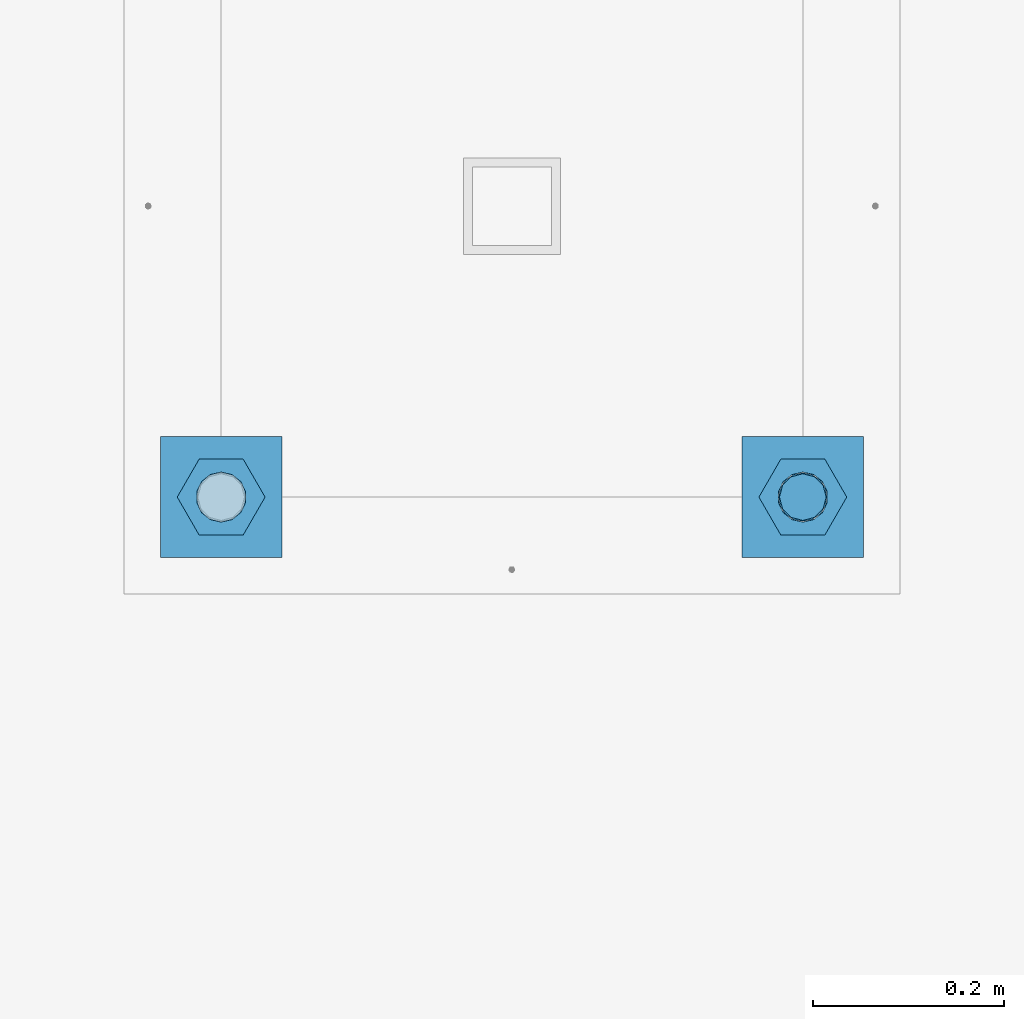
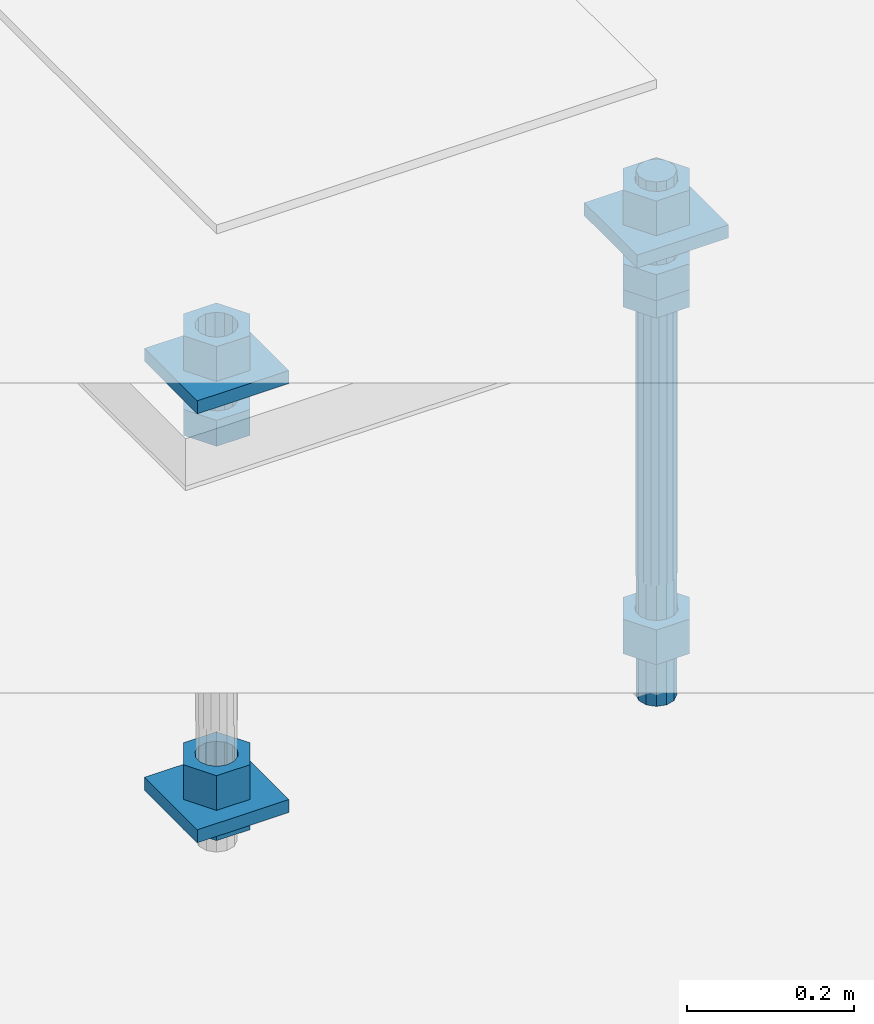
# One storey, part 2733 of 3843: 12 beams, 1 element without a shape of its own.
"""IFC2X3 building model written with IfcOpenShell, lengths in millimetres."""

from ifc_helpers import new_model, si_unit, frame, origin_with_axes, place, context, subcontext, project, spatial, faceted_brep, material, type_object, element, aggregate, save


model = new_model("IFC2X3")

# Units and contexts
model_context = context("Model", 3, precision=1e-05, world=origin_with_axes())
body_context = subcontext(model_context, "Body", "Model", "MODEL_VIEW")
ifc_project = project(units=[si_unit("LENGTHUNIT", "METRE", prefix="MILLI"), si_unit("AREAUNIT", "SQUARE_METRE"), si_unit("VOLUMEUNIT", "CUBIC_METRE"), si_unit("MASSUNIT", "GRAM", prefix="KILO"), si_unit("TIMEUNIT", "SECOND"), si_unit("PLANEANGLEUNIT", "RADIAN"), si_unit("SOLIDANGLEUNIT", "STERADIAN"), si_unit("THERMODYNAMICTEMPERATUREUNIT", "DEGREE_CELSIUS"), si_unit("LUMINOUSINTENSITYUNIT", "LUMEN")], contexts=[model_context])

# Site, building, storey
site_placement = place(None, origin_with_axes())
site = spatial("IfcSite", under=ifc_project, at=site_placement, CompositionType="ELEMENT")
building_placement = place(site_placement, origin_with_axes())
building = spatial("IfcBuilding", under=site, at=building_placement, Name="Undefined", CompositionType="ELEMENT")
storey_placement = place(building_placement, origin_with_axes())
storey = spatial("IfcBuildingStorey", under=building, at=storey_placement, Name="Undefined", CompositionType="ELEMENT", Elevation=0.0)

# Assembly, beams
assembly_placement = place(storey_placement, origin_with_axes())
assembly = element("IfcElementAssembly", 1, at=assembly_placement, inside=storey, Name="TEMPLATE", AssemblyPlace="NOTDEFINED", PredefinedType="RIGID_FRAME")
ifc_material_1 = material(Name="STEEL/A36")
beam_type_1 = type_object("IfcBeamType", PredefinedType="NOTDEFINED")
beam_1_placement = place(assembly_placement, frame((115798.6, 38188.9000015259, 29873.575), z_axis=(1.0, 0.0, 0.0), x_axis=(0.0, 1.0, 0.0)))
beam_1 = element("IfcBeam", 2, at=beam_1_placement, type_object=beam_type_1, material=ifc_material_1, Name="WASHER_PLATE", context=body_context, shape_type="Brep", body=[
    faceted_brep([(0.0, 9.52500000000146, -63.5), (0.0, 9.52500000000146, 63.5), (127.0, 9.52500000000146, 63.5), (127.0, 9.52500000000146, -63.5), (0.0, -9.52500000000146, 63.5), (127.0, -9.52500000000146, 63.5), (0.0, -9.52500000000146, -63.5), (127.0, -9.52500000000146, -63.5)], [[[0, 1, 2, 3]], [[1, 4, 5, 2]], [[4, 6, 7, 5]], [[6, 0, 3, 7]], [[5, 7, 3, 2]], [[6, 4, 1, 0]]]),
])
beam_2_placement = place(assembly_placement, frame((116408.2, 38188.9000015259, 29873.575), z_axis=(1.0, 0.0, 0.0), x_axis=(0.0, 1.0, 0.0)))
beam_2 = element("IfcBeam", 3, at=beam_2_placement, type_object=beam_type_1, material=ifc_material_1, Name="WASHER_PLATE", context=body_context, shape_type="Brep", body=[
    faceted_brep([(0.0, 9.52500000000146, -63.5), (0.0, 9.52500000000146, 63.5), (127.0, 9.52500000000146, 63.5), (127.0, 9.52500000000146, -63.5), (0.0, -9.52500000000146, 63.5), (127.0, -9.52500000000146, 63.5), (0.0, -9.52500000000146, -63.5), (127.0, -9.52500000000146, -63.5)], [[[0, 1, 2, 3]], [[1, 4, 5, 2]], [[4, 6, 7, 5]], [[6, 0, 3, 7]], [[5, 7, 3, 2]], [[6, 4, 1, 0]]]),
])
beam_3_placement = place(assembly_placement, frame((115798.6, 38188.9000015259, 29244.925), z_axis=(1.0, 0.0, 0.0), x_axis=(0.0, 1.0, 0.0)))
beam_3 = element("IfcBeam", 4, at=beam_3_placement, type_object=beam_type_1, material=ifc_material_1, Name="WASHER_PLATE", context=body_context, shape_type="Brep", body=[
    faceted_brep([(0.0, 9.52500000000146, -63.5), (0.0, 9.52500000000146, 63.5), (127.0, 9.52500000000146, 63.5), (127.0, 9.52500000000146, -63.5), (0.0, -9.52500000000146, 63.5), (127.0, -9.52500000000146, 63.5), (0.0, -9.52500000000146, -63.5), (127.0, -9.52500000000146, -63.5)], [[[0, 1, 2, 3]], [[1, 4, 5, 2]], [[4, 6, 7, 5]], [[6, 0, 3, 7]], [[5, 7, 3, 2]], [[6, 4, 1, 0]]]),
])
beam_type_2 = type_object("IfcBeamType", Name="2_HALF_NUT", PredefinedType="NOTDEFINED")
beam_4_placement = place(assembly_placement, frame((116408.2, 38252.4000015259, 29787.85), z_axis=(0.0, 1.0, 0.0), x_axis=(0.0, 0.0, -1.0)))
beam_4 = element("IfcBeam", 5, at=beam_4_placement, type_object=beam_type_2, material=ifc_material_1, Name="NUT", ObjectType="2_HALF_NUT", context=body_context, shape_type="Brep", body=[
    faceted_brep([(0.0, -46.0369987487793, 0.0), (0.0, -23.0184993743896, -39.869213104248), (25.4000000000015, -23.0184993743896, -39.869213104248), (25.4000000000015, -46.0369987487793, 0.0), (0.0, 23.0184993743896, -39.869213104248), (25.4000000000015, 23.0184993743896, -39.869213104248), (0.0, 46.0369987487793, 0.0), (25.4000000000015, 46.0369987487793, 0.0), (0.0, 23.0184993743896, 39.869213104248), (25.4000000000015, 23.0184993743896, 39.869213104248), (0.0, -23.0184993743896, 39.869213104248), (25.4000000000015, -23.0184993743896, 39.869213104248), (0.0, 0.0, 26.1940002441406), (0.0, 11.3650617044477, 23.5999013092805), (25.4000000000015, 11.3650617044477, 23.5999013092805), (25.4000000000015, 0.0, 26.1940002441406), (0.0, 20.4791109456419, 16.3316083006721), (25.4000000000015, 20.4791109456419, 16.3316083006721), (0.0, 25.5370200498292, 5.82867859874386), (25.4000000000015, 25.5370200498292, 5.82867859874386), (0.0, 25.5370200498292, -5.82867859874386), (25.4000000000015, 25.5370200498292, -5.82867859874386), (0.0, 20.4791109456419, -16.3316083006721), (25.4000000000015, 20.4791109456419, -16.3316083006721), (0.0, 11.3650617044477, -23.5999013092805), (25.4000000000015, 11.3650617044477, -23.5999013092805), (0.0, 0.0, -26.1940002441406), (25.4000000000015, 0.0, -26.1940002441406), (0.0, -11.3650617044477, -23.5999013092805), (25.4000000000015, -11.3650617044477, -23.5999013092805), (0.0, -20.4791109456419, -16.3316083006721), (25.4000000000015, -20.4791109456419, -16.3316083006721), (0.0, -25.5370200498292, -5.82867859874386), (25.4000000000015, -25.5370200498292, -5.82867859874386), (0.0, -25.5370200498292, 5.82867859874386), (25.4000000000015, -25.5370200498292, 5.82867859874386), (0.0, -20.4791109456419, 16.3316083006721), (25.4000000000015, -20.4791109456419, 16.3316083006721), (0.0, -11.3650617044477, 23.5999013092805), (25.4000000000015, -11.3650617044477, 23.5999013092805)], [[[0, 1, 2, 3]], [[1, 4, 5, 2]], [[4, 6, 7, 5]], [[6, 8, 9, 7]], [[8, 10, 11, 9]], [[10, 0, 3, 11]], [[12, 13, 14, 15]], [[13, 16, 17, 14]], [[16, 18, 19, 17]], [[18, 20, 21, 19]], [[20, 22, 23, 21]], [[22, 24, 25, 23]], [[24, 26, 27, 25]], [[26, 28, 29, 27]], [[28, 30, 31, 29]], [[30, 32, 33, 31]], [[32, 34, 35, 33]], [[34, 36, 37, 35]], [[36, 38, 39, 37]], [[38, 12, 15, 39]], [[5, 7, 9, 11, 3, 2], [17, 19, 21, 23, 25, 27, 29, 31, 33, 35, 37, 39, 15, 14]], [[10, 8, 6, 4, 1, 0], [38, 36, 34, 32, 30, 28, 26, 24, 22, 20, 18, 16, 13, 12]]]),
])
beam_5_placement = place(assembly_placement, frame((115798.6, 38252.4000015259, 29235.4), z_axis=(0.0, 1.0, 0.0), x_axis=(0.0, 0.0, -1.0)))
beam_5 = element("IfcBeam", 6, at=beam_5_placement, type_object=beam_type_2, material=ifc_material_1, Name="NUT", ObjectType="2_HALF_NUT", context=body_context, shape_type="Brep", body=[
    faceted_brep([(0.0, -46.0369987487793, 0.0), (0.0, -23.0184993743896, -39.869213104248), (25.4000000000015, -23.0184993743896, -39.869213104248), (25.4000000000015, -46.0369987487793, 0.0), (0.0, 23.0184993743896, -39.869213104248), (25.4000000000015, 23.0184993743896, -39.869213104248), (0.0, 46.0369987487793, 0.0), (25.4000000000015, 46.0369987487793, 0.0), (0.0, 23.0184993743896, 39.869213104248), (25.4000000000015, 23.0184993743896, 39.869213104248), (0.0, -23.0184993743896, 39.869213104248), (25.4000000000015, -23.0184993743896, 39.869213104248), (0.0, 0.0, 26.1940002441406), (0.0, 11.3650617044477, 23.5999013092805), (25.4000000000015, 11.3650617044477, 23.5999013092805), (25.4000000000015, 0.0, 26.1940002441406), (0.0, 20.4791109456419, 16.3316083006721), (25.4000000000015, 20.4791109456419, 16.3316083006721), (0.0, 25.5370200498292, 5.82867859874386), (25.4000000000015, 25.5370200498292, 5.82867859874386), (0.0, 25.5370200498292, -5.82867859874386), (25.4000000000015, 25.5370200498292, -5.82867859874386), (0.0, 20.4791109456419, -16.3316083006721), (25.4000000000015, 20.4791109456419, -16.3316083006721), (0.0, 11.3650617044477, -23.5999013092805), (25.4000000000015, 11.3650617044477, -23.5999013092805), (0.0, 0.0, -26.1940002441406), (25.4000000000015, 0.0, -26.1940002441406), (0.0, -11.3650617044477, -23.5999013092805), (25.4000000000015, -11.3650617044477, -23.5999013092805), (0.0, -20.4791109456419, -16.3316083006721), (25.4000000000015, -20.4791109456419, -16.3316083006721), (0.0, -25.5370200498292, -5.82867859874386), (25.4000000000015, -25.5370200498292, -5.82867859874386), (0.0, -25.5370200498292, 5.82867859874386), (25.4000000000015, -25.5370200498292, 5.82867859874386), (0.0, -20.4791109456419, 16.3316083006721), (25.4000000000015, -20.4791109456419, 16.3316083006721), (0.0, -11.3650617044477, 23.5999013092805), (25.4000000000015, -11.3650617044477, 23.5999013092805)], [[[0, 1, 2, 3]], [[1, 4, 5, 2]], [[4, 6, 7, 5]], [[6, 8, 9, 7]], [[8, 10, 11, 9]], [[10, 0, 3, 11]], [[12, 13, 14, 15]], [[13, 16, 17, 14]], [[16, 18, 19, 17]], [[18, 20, 21, 19]], [[20, 22, 23, 21]], [[22, 24, 25, 23]], [[24, 26, 27, 25]], [[26, 28, 29, 27]], [[28, 30, 31, 29]], [[30, 32, 33, 31]], [[32, 34, 35, 33]], [[34, 36, 37, 35]], [[36, 38, 39, 37]], [[38, 12, 15, 39]], [[5, 7, 9, 11, 3, 2], [17, 19, 21, 23, 25, 27, 29, 31, 33, 35, 37, 39, 15, 14]], [[10, 8, 6, 4, 1, 0], [38, 36, 34, 32, 30, 28, 26, 24, 22, 20, 18, 16, 13, 12]]]),
])
beam_type_3 = type_object("IfcBeamType", Name="2_HEAVY_HEX_NUT", PredefinedType="NOTDEFINED")
beam_6_placement = place(assembly_placement, frame((115798.6, 38252.4000015259, 29825.95), z_axis=(0.0, 1.0, 0.0), x_axis=(0.0, 0.0, -1.0)))
beam_6 = element("IfcBeam", 7, at=beam_6_placement, type_object=beam_type_3, material=ifc_material_1, Name="NUT", ObjectType="2_HEAVY_HEX_NUT", context=body_context, shape_type="Brep", body=[
    faceted_brep([(0.0, -46.0369987487793, 0.0), (0.0, -23.0184993743896, -39.869213104248), (38.0999999999985, -23.0184993743896, -39.869213104248), (38.0999999999985, -46.0369987487793, 0.0), (0.0, 23.0184993743896, -39.869213104248), (38.0999999999985, 23.0184993743896, -39.869213104248), (0.0, 46.0369987487793, 0.0), (38.0999999999985, 46.0369987487793, 0.0), (0.0, 23.0184993743896, 39.869213104248), (38.0999999999985, 23.0184993743896, 39.869213104248), (0.0, -23.0184993743896, 39.869213104248), (38.0999999999985, -23.0184993743896, 39.869213104248), (0.0, 0.0, 26.1940002441406), (0.0, 11.3650617044477, 23.5999013092805), (38.0999999999985, 11.3650617044477, 23.5999013092805), (38.0999999999985, 0.0, 26.1940002441406), (0.0, 20.4791109456419, 16.3316083006721), (38.0999999999985, 20.4791109456419, 16.3316083006721), (0.0, 25.5370200498292, 5.82867859874386), (38.0999999999985, 25.5370200498292, 5.82867859874386), (0.0, 25.5370200498292, -5.82867859874386), (38.0999999999985, 25.5370200498292, -5.82867859874386), (0.0, 20.4791109456419, -16.3316083006721), (38.0999999999985, 20.4791109456419, -16.3316083006721), (0.0, 11.3650617044477, -23.5999013092805), (38.0999999999985, 11.3650617044477, -23.5999013092805), (0.0, 0.0, -26.1940002441406), (38.0999999999985, 0.0, -26.1940002441406), (0.0, -11.3650617044477, -23.5999013092805), (38.0999999999985, -11.3650617044477, -23.5999013092805), (0.0, -20.4791109456419, -16.3316083006721), (38.0999999999985, -20.4791109456419, -16.3316083006721), (0.0, -25.5370200498292, -5.82867859874386), (38.0999999999985, -25.5370200498292, -5.82867859874386), (0.0, -25.5370200498292, 5.82867859874386), (38.0999999999985, -25.5370200498292, 5.82867859874386), (0.0, -20.4791109456419, 16.3316083006721), (38.0999999999985, -20.4791109456419, 16.3316083006721), (0.0, -11.3650617044477, 23.5999013092805), (38.0999999999985, -11.3650617044477, 23.5999013092805)], [[[0, 1, 2, 3]], [[1, 4, 5, 2]], [[4, 6, 7, 5]], [[6, 8, 9, 7]], [[8, 10, 11, 9]], [[10, 0, 3, 11]], [[12, 13, 14, 15]], [[13, 16, 17, 14]], [[16, 18, 19, 17]], [[18, 20, 21, 19]], [[20, 22, 23, 21]], [[22, 24, 25, 23]], [[24, 26, 27, 25]], [[26, 28, 29, 27]], [[28, 30, 31, 29]], [[30, 32, 33, 31]], [[32, 34, 35, 33]], [[34, 36, 37, 35]], [[36, 38, 39, 37]], [[38, 12, 15, 39]], [[5, 7, 9, 11, 3, 2], [17, 19, 21, 23, 25, 27, 29, 31, 33, 35, 37, 39, 15, 14]], [[10, 8, 6, 4, 1, 0], [38, 36, 34, 32, 30, 28, 26, 24, 22, 20, 18, 16, 13, 12]]]),
])
beam_7_placement = place(assembly_placement, frame((115798.6, 38252.4000015259, 29933.9), z_axis=(0.0, 1.0, 0.0), x_axis=(0.0, 0.0, -1.0)))
beam_7 = element("IfcBeam", 8, at=beam_7_placement, type_object=beam_type_3, material=ifc_material_1, Name="NUT", ObjectType="2_HEAVY_HEX_NUT", context=body_context, shape_type="Brep", body=[
    faceted_brep([(0.0, -46.0369987487793, 0.0), (0.0, -23.0184993743896, -39.869213104248), (50.7999999999993, -23.0184993743896, -39.869213104248), (50.7999999999993, -46.0369987487793, 0.0), (0.0, 23.0184993743896, -39.869213104248), (50.7999999999993, 23.0184993743896, -39.869213104248), (0.0, 46.0369987487793, 0.0), (50.7999999999993, 46.0369987487793, 0.0), (0.0, 23.0184993743896, 39.869213104248), (50.7999999999993, 23.0184993743896, 39.869213104248), (0.0, -23.0184993743896, 39.869213104248), (50.7999999999993, -23.0184993743896, 39.869213104248), (0.0, 0.0, 26.1940002441406), (0.0, 11.3650617044477, 23.5999013092805), (50.7999999999993, 11.3650617044477, 23.5999013092805), (50.7999999999993, 0.0, 26.1940002441406), (0.0, 20.4791109456419, 16.3316083006721), (50.7999999999993, 20.4791109456419, 16.3316083006721), (0.0, 25.5370200498292, 5.82867859874386), (50.7999999999993, 25.5370200498292, 5.82867859874386), (0.0, 25.5370200498292, -5.82867859874386), (50.7999999999993, 25.5370200498292, -5.82867859874386), (0.0, 20.4791109456419, -16.3316083006721), (50.7999999999993, 20.4791109456419, -16.3316083006721), (0.0, 11.3650617044477, -23.5999013092805), (50.7999999999993, 11.3650617044477, -23.5999013092805), (0.0, 0.0, -26.1940002441406), (50.7999999999993, 0.0, -26.1940002441406), (0.0, -11.3650617044477, -23.5999013092805), (50.7999999999993, -11.3650617044477, -23.5999013092805), (0.0, -20.4791109456419, -16.3316083006721), (50.7999999999993, -20.4791109456419, -16.3316083006721), (0.0, -25.5370200498292, -5.82867859874386), (50.7999999999993, -25.5370200498292, -5.82867859874386), (0.0, -25.5370200498292, 5.82867859874386), (50.7999999999993, -25.5370200498292, 5.82867859874386), (0.0, -20.4791109456419, 16.3316083006721), (50.7999999999993, -20.4791109456419, 16.3316083006721), (0.0, -11.3650617044477, 23.5999013092805), (50.7999999999993, -11.3650617044477, 23.5999013092805)], [[[0, 1, 2, 3]], [[1, 4, 5, 2]], [[4, 6, 7, 5]], [[6, 8, 9, 7]], [[8, 10, 11, 9]], [[10, 0, 3, 11]], [[12, 13, 14, 15]], [[13, 16, 17, 14]], [[16, 18, 19, 17]], [[18, 20, 21, 19]], [[20, 22, 23, 21]], [[22, 24, 25, 23]], [[24, 26, 27, 25]], [[26, 28, 29, 27]], [[28, 30, 31, 29]], [[30, 32, 33, 31]], [[32, 34, 35, 33]], [[34, 36, 37, 35]], [[36, 38, 39, 37]], [[38, 12, 15, 39]], [[5, 7, 9, 11, 3, 2], [17, 19, 21, 23, 25, 27, 29, 31, 33, 35, 37, 39, 15, 14]], [[10, 8, 6, 4, 1, 0], [38, 36, 34, 32, 30, 28, 26, 24, 22, 20, 18, 16, 13, 12]]]),
])
beam_8_placement = place(assembly_placement, frame((115798.6, 38252.4000015259, 29305.25), z_axis=(0.0, 1.0, 0.0), x_axis=(0.0, 0.0, -1.0)))
beam_8 = element("IfcBeam", 9, at=beam_8_placement, type_object=beam_type_3, material=ifc_material_1, Name="NUT", ObjectType="2_HEAVY_HEX_NUT", context=body_context, shape_type="Brep", body=[
    faceted_brep([(0.0, -46.0369987487793, 0.0), (0.0, -23.0184993743896, -39.869213104248), (50.7999999999993, -23.0184993743896, -39.869213104248), (50.7999999999993, -46.0369987487793, 0.0), (0.0, 23.0184993743896, -39.869213104248), (50.7999999999993, 23.0184993743896, -39.869213104248), (0.0, 46.0369987487793, 0.0), (50.7999999999993, 46.0369987487793, 0.0), (0.0, 23.0184993743896, 39.869213104248), (50.7999999999993, 23.0184993743896, 39.869213104248), (0.0, -23.0184993743896, 39.869213104248), (50.7999999999993, -23.0184993743896, 39.869213104248), (0.0, 0.0, 26.1940002441406), (0.0, 11.3650617044477, 23.5999013092805), (50.7999999999993, 11.3650617044477, 23.5999013092805), (50.7999999999993, 0.0, 26.1940002441406), (0.0, 20.4791109456419, 16.3316083006721), (50.7999999999993, 20.4791109456419, 16.3316083006721), (0.0, 25.5370200498292, 5.82867859874386), (50.7999999999993, 25.5370200498292, 5.82867859874386), (0.0, 25.5370200498292, -5.82867859874386), (50.7999999999993, 25.5370200498292, -5.82867859874386), (0.0, 20.4791109456419, -16.3316083006721), (50.7999999999993, 20.4791109456419, -16.3316083006721), (0.0, 11.3650617044477, -23.5999013092805), (50.7999999999993, 11.3650617044477, -23.5999013092805), (0.0, 0.0, -26.1940002441406), (50.7999999999993, 0.0, -26.1940002441406), (0.0, -11.3650617044477, -23.5999013092805), (50.7999999999993, -11.3650617044477, -23.5999013092805), (0.0, -20.4791109456419, -16.3316083006721), (50.7999999999993, -20.4791109456419, -16.3316083006721), (0.0, -25.5370200498292, -5.82867859874386), (50.7999999999993, -25.5370200498292, -5.82867859874386), (0.0, -25.5370200498292, 5.82867859874386), (50.7999999999993, -25.5370200498292, 5.82867859874386), (0.0, -20.4791109456419, 16.3316083006721), (50.7999999999993, -20.4791109456419, 16.3316083006721), (0.0, -11.3650617044477, 23.5999013092805), (50.7999999999993, -11.3650617044477, 23.5999013092805)], [[[0, 1, 2, 3]], [[1, 4, 5, 2]], [[4, 6, 7, 5]], [[6, 8, 9, 7]], [[8, 10, 11, 9]], [[10, 0, 3, 11]], [[12, 13, 14, 15]], [[13, 16, 17, 14]], [[16, 18, 19, 17]], [[18, 20, 21, 19]], [[20, 22, 23, 21]], [[22, 24, 25, 23]], [[24, 26, 27, 25]], [[26, 28, 29, 27]], [[28, 30, 31, 29]], [[30, 32, 33, 31]], [[32, 34, 35, 33]], [[34, 36, 37, 35]], [[36, 38, 39, 37]], [[38, 12, 15, 39]], [[5, 7, 9, 11, 3, 2], [17, 19, 21, 23, 25, 27, 29, 31, 33, 35, 37, 39, 15, 14]], [[10, 8, 6, 4, 1, 0], [38, 36, 34, 32, 30, 28, 26, 24, 22, 20, 18, 16, 13, 12]]]),
])
beam_9_placement = place(assembly_placement, frame((116408.2, 38252.4000015259, 29825.95), z_axis=(0.0, 1.0, 0.0), x_axis=(0.0, 0.0, -1.0)))
beam_9 = element("IfcBeam", 10, at=beam_9_placement, type_object=beam_type_3, material=ifc_material_1, Name="NUT", ObjectType="2_HEAVY_HEX_NUT", context=body_context, shape_type="Brep", body=[
    faceted_brep([(0.0, -46.0369987487793, 0.0), (0.0, -23.0184993743896, -39.869213104248), (38.0999999999985, -23.0184993743896, -39.869213104248), (38.0999999999985, -46.0369987487793, 0.0), (0.0, 23.0184993743896, -39.869213104248), (38.0999999999985, 23.0184993743896, -39.869213104248), (0.0, 46.0369987487793, 0.0), (38.0999999999985, 46.0369987487793, 0.0), (0.0, 23.0184993743896, 39.869213104248), (38.0999999999985, 23.0184993743896, 39.869213104248), (0.0, -23.0184993743896, 39.869213104248), (38.0999999999985, -23.0184993743896, 39.869213104248), (0.0, 0.0, 26.1940002441406), (0.0, 11.3650617044477, 23.5999013092805), (38.0999999999985, 11.3650617044477, 23.5999013092805), (38.0999999999985, 0.0, 26.1940002441406), (0.0, 20.4791109456419, 16.3316083006721), (38.0999999999985, 20.4791109456419, 16.3316083006721), (0.0, 25.5370200498292, 5.82867859874386), (38.0999999999985, 25.5370200498292, 5.82867859874386), (0.0, 25.5370200498292, -5.82867859874386), (38.0999999999985, 25.5370200498292, -5.82867859874386), (0.0, 20.4791109456419, -16.3316083006721), (38.0999999999985, 20.4791109456419, -16.3316083006721), (0.0, 11.3650617044477, -23.5999013092805), (38.0999999999985, 11.3650617044477, -23.5999013092805), (0.0, 0.0, -26.1940002441406), (38.0999999999985, 0.0, -26.1940002441406), (0.0, -11.3650617044477, -23.5999013092805), (38.0999999999985, -11.3650617044477, -23.5999013092805), (0.0, -20.4791109456419, -16.3316083006721), (38.0999999999985, -20.4791109456419, -16.3316083006721), (0.0, -25.5370200498292, -5.82867859874386), (38.0999999999985, -25.5370200498292, -5.82867859874386), (0.0, -25.5370200498292, 5.82867859874386), (38.0999999999985, -25.5370200498292, 5.82867859874386), (0.0, -20.4791109456419, 16.3316083006721), (38.0999999999985, -20.4791109456419, 16.3316083006721), (0.0, -11.3650617044477, 23.5999013092805), (38.0999999999985, -11.3650617044477, 23.5999013092805)], [[[0, 1, 2, 3]], [[1, 4, 5, 2]], [[4, 6, 7, 5]], [[6, 8, 9, 7]], [[8, 10, 11, 9]], [[10, 0, 3, 11]], [[12, 13, 14, 15]], [[13, 16, 17, 14]], [[16, 18, 19, 17]], [[18, 20, 21, 19]], [[20, 22, 23, 21]], [[22, 24, 25, 23]], [[24, 26, 27, 25]], [[26, 28, 29, 27]], [[28, 30, 31, 29]], [[30, 32, 33, 31]], [[32, 34, 35, 33]], [[34, 36, 37, 35]], [[36, 38, 39, 37]], [[38, 12, 15, 39]], [[5, 7, 9, 11, 3, 2], [17, 19, 21, 23, 25, 27, 29, 31, 33, 35, 37, 39, 15, 14]], [[10, 8, 6, 4, 1, 0], [38, 36, 34, 32, 30, 28, 26, 24, 22, 20, 18, 16, 13, 12]]]),
])
beam_10_placement = place(assembly_placement, frame((116408.2, 38252.4000015259, 29933.9), z_axis=(0.0, 1.0, 0.0), x_axis=(0.0, 0.0, -1.0)))
beam_10 = element("IfcBeam", 11, at=beam_10_placement, type_object=beam_type_3, material=ifc_material_1, Name="NUT", ObjectType="2_HEAVY_HEX_NUT", context=body_context, shape_type="Brep", body=[
    faceted_brep([(0.0, -46.0369987487793, 0.0), (0.0, -23.0184993743896, -39.869213104248), (50.7999999999993, -23.0184993743896, -39.869213104248), (50.7999999999993, -46.0369987487793, 0.0), (0.0, 23.0184993743896, -39.869213104248), (50.7999999999993, 23.0184993743896, -39.869213104248), (0.0, 46.0369987487793, 0.0), (50.7999999999993, 46.0369987487793, 0.0), (0.0, 23.0184993743896, 39.869213104248), (50.7999999999993, 23.0184993743896, 39.869213104248), (0.0, -23.0184993743896, 39.869213104248), (50.7999999999993, -23.0184993743896, 39.869213104248), (0.0, 0.0, 26.1940002441406), (0.0, 11.3650617044477, 23.5999013092805), (50.7999999999993, 11.3650617044477, 23.5999013092805), (50.7999999999993, 0.0, 26.1940002441406), (0.0, 20.4791109456419, 16.3316083006721), (50.7999999999993, 20.4791109456419, 16.3316083006721), (0.0, 25.5370200498292, 5.82867859874386), (50.7999999999993, 25.5370200498292, 5.82867859874386), (0.0, 25.5370200498292, -5.82867859874386), (50.7999999999993, 25.5370200498292, -5.82867859874386), (0.0, 20.4791109456419, -16.3316083006721), (50.7999999999993, 20.4791109456419, -16.3316083006721), (0.0, 11.3650617044477, -23.5999013092805), (50.7999999999993, 11.3650617044477, -23.5999013092805), (0.0, 0.0, -26.1940002441406), (50.7999999999993, 0.0, -26.1940002441406), (0.0, -11.3650617044477, -23.5999013092805), (50.7999999999993, -11.3650617044477, -23.5999013092805), (0.0, -20.4791109456419, -16.3316083006721), (50.7999999999993, -20.4791109456419, -16.3316083006721), (0.0, -25.5370200498292, -5.82867859874386), (50.7999999999993, -25.5370200498292, -5.82867859874386), (0.0, -25.5370200498292, 5.82867859874386), (50.7999999999993, -25.5370200498292, 5.82867859874386), (0.0, -20.4791109456419, 16.3316083006721), (50.7999999999993, -20.4791109456419, 16.3316083006721), (0.0, -11.3650617044477, 23.5999013092805), (50.7999999999993, -11.3650617044477, 23.5999013092805)], [[[0, 1, 2, 3]], [[1, 4, 5, 2]], [[4, 6, 7, 5]], [[6, 8, 9, 7]], [[8, 10, 11, 9]], [[10, 0, 3, 11]], [[12, 13, 14, 15]], [[13, 16, 17, 14]], [[16, 18, 19, 17]], [[18, 20, 21, 19]], [[20, 22, 23, 21]], [[22, 24, 25, 23]], [[24, 26, 27, 25]], [[26, 28, 29, 27]], [[28, 30, 31, 29]], [[30, 32, 33, 31]], [[32, 34, 35, 33]], [[34, 36, 37, 35]], [[36, 38, 39, 37]], [[38, 12, 15, 39]], [[5, 7, 9, 11, 3, 2], [17, 19, 21, 23, 25, 27, 29, 31, 33, 35, 37, 39, 15, 14]], [[10, 8, 6, 4, 1, 0], [38, 36, 34, 32, 30, 28, 26, 24, 22, 20, 18, 16, 13, 12]]]),
])
beam_11_placement = place(assembly_placement, frame((116408.2, 38252.4000015259, 29305.25), z_axis=(0.0, 1.0, 0.0), x_axis=(0.0, 0.0, -1.0)))
beam_11 = element("IfcBeam", 12, at=beam_11_placement, type_object=beam_type_3, material=ifc_material_1, Name="NUT", ObjectType="2_HEAVY_HEX_NUT", context=body_context, shape_type="Brep", body=[
    faceted_brep([(0.0, -46.0369987487793, 0.0), (0.0, -23.0184993743896, -39.869213104248), (50.7999999999993, -23.0184993743896, -39.869213104248), (50.7999999999993, -46.0369987487793, 0.0), (0.0, 23.0184993743896, -39.869213104248), (50.7999999999993, 23.0184993743896, -39.869213104248), (0.0, 46.0369987487793, 0.0), (50.7999999999993, 46.0369987487793, 0.0), (0.0, 23.0184993743896, 39.869213104248), (50.7999999999993, 23.0184993743896, 39.869213104248), (0.0, -23.0184993743896, 39.869213104248), (50.7999999999993, -23.0184993743896, 39.869213104248), (0.0, 0.0, 26.1940002441406), (0.0, 11.3650617044477, 23.5999013092805), (50.7999999999993, 11.3650617044477, 23.5999013092805), (50.7999999999993, 0.0, 26.1940002441406), (0.0, 20.4791109456419, 16.3316083006721), (50.7999999999993, 20.4791109456419, 16.3316083006721), (0.0, 25.5370200498292, 5.82867859874386), (50.7999999999993, 25.5370200498292, 5.82867859874386), (0.0, 25.5370200498292, -5.82867859874386), (50.7999999999993, 25.5370200498292, -5.82867859874386), (0.0, 20.4791109456419, -16.3316083006721), (50.7999999999993, 20.4791109456419, -16.3316083006721), (0.0, 11.3650617044477, -23.5999013092805), (50.7999999999993, 11.3650617044477, -23.5999013092805), (0.0, 0.0, -26.1940002441406), (50.7999999999993, 0.0, -26.1940002441406), (0.0, -11.3650617044477, -23.5999013092805), (50.7999999999993, -11.3650617044477, -23.5999013092805), (0.0, -20.4791109456419, -16.3316083006721), (50.7999999999993, -20.4791109456419, -16.3316083006721), (0.0, -25.5370200498292, -5.82867859874386), (50.7999999999993, -25.5370200498292, -5.82867859874386), (0.0, -25.5370200498292, 5.82867859874386), (50.7999999999993, -25.5370200498292, 5.82867859874386), (0.0, -20.4791109456419, 16.3316083006721), (50.7999999999993, -20.4791109456419, 16.3316083006721), (0.0, -11.3650617044477, 23.5999013092805), (50.7999999999993, -11.3650617044477, 23.5999013092805)], [[[0, 1, 2, 3]], [[1, 4, 5, 2]], [[4, 6, 7, 5]], [[6, 8, 9, 7]], [[8, 10, 11, 9]], [[10, 0, 3, 11]], [[12, 13, 14, 15]], [[13, 16, 17, 14]], [[16, 18, 19, 17]], [[18, 20, 21, 19]], [[20, 22, 23, 21]], [[22, 24, 25, 23]], [[24, 26, 27, 25]], [[26, 28, 29, 27]], [[28, 30, 31, 29]], [[30, 32, 33, 31]], [[32, 34, 35, 33]], [[34, 36, 37, 35]], [[36, 38, 39, 37]], [[38, 12, 15, 39]], [[5, 7, 9, 11, 3, 2], [17, 19, 21, 23, 25, 27, 29, 31, 33, 35, 37, 39, 15, 14]], [[10, 8, 6, 4, 1, 0], [38, 36, 34, 32, 30, 28, 26, 24, 22, 20, 18, 16, 13, 12]]]),
])
ifc_material_2 = material()
beam_type_4 = type_object("IfcBeamType", PredefinedType="NOTDEFINED")
beam_12_placement = place(assembly_placement, frame((116408.2, 38252.4000015259, 29762.45), z_axis=(0.0, 1.0, 0.0), x_axis=(0.0, 0.0, -1.0)))
beam_12 = element("IfcBeam", 13, at=beam_12_placement, type_object=beam_type_4, material=ifc_material_2, Name="ANCHOR_ROD", context=body_context, shape_type="Brep", body=[
    faceted_brep([(-184.150000000001, -21.217622392709, 12.25), (-184.150000000001, -12.2499999999854, 21.2176223927163), (-184.150000000001, 1.45519152283669e-11, 24.5), (-184.150000000001, 12.2500000000146, 21.2176223927163), (-184.150000000001, 21.2176223927381, 12.25), (-184.150000000001, 24.5000000000146, 0.0), (-184.150000000001, 21.2176223927381, -12.25), (-184.150000000001, 12.2500000000146, -21.2176223927163), (-184.150000000001, 1.45519152283669e-11, -24.5), (-184.150000000001, -12.2499999999854, -21.2176223927163), (-184.150000000001, -21.217622392709, -12.25), (-184.150000000001, -24.4999999999854, 0.0), (0.0, 24.5000000000146, 0.0), (0.0, 21.2176223927381, -12.25), (0.0, 12.2500000000146, -21.2176223927163), (0.0, 1.45519152283669e-11, -24.5), (0.0, -12.2499999999854, -21.2176223927163), (0.0, -21.217622392709, -12.25), (0.0, -24.4999999999854, 0.0), (0.0, -21.217622392709, 12.25), (0.0, -12.2499999999854, 21.2176223927163), (0.0, 1.45519152283669e-11, 24.5), (0.0, 12.2500000000146, 21.2176223927163), (0.0, 21.2176223927381, 12.25), (0.0, -23.4665401257807, 9.72015918207035), (0.0, -17.9605122421344, 17.9605122421417), (0.0, -9.72015918207762, 23.466540125788), (0.0, 0.0, 25.4000000000015), (0.0, 9.72015918207762, 23.466540125788), (0.0, 17.9605122421344, 17.9605122421417), (0.0, 23.4665401257807, 9.72015918207035), (0.0, 25.3999996185303, 0.0), (0.0, 23.4665401257807, -9.72015918207035), (0.0, 17.9605122421344, -17.9605122421417), (0.0, 9.72015918207762, -23.466540125788), (0.0, 0.0, -25.4000000000015), (0.0, -9.72015918207762, -23.466540125788), (0.0, -17.9605122421344, -17.9605122421417), (0.0, -23.4665401257807, -9.72015918207035), (0.0, -25.3999996185303, 0.0), (406.399999999998, -25.3999999999942, 0.0), (406.399999999998, -23.4665401257807, 9.72015918207035), (406.399999999998, -17.9605122421344, 17.9605122421417), (406.399999999998, -9.72015918207762, 23.466540125788), (406.399999999998, 0.0, 25.4000000000015), (406.399999999998, 9.72015918207762, 23.466540125788), (406.399999999998, 17.9605122421344, 17.9605122421417), (406.399999999998, 23.4665401257807, 9.72015918207035), (406.399999999998, 25.3999999999942, 0.0), (406.399999999998, 23.4665401257807, -9.72015918207035), (406.399999999998, 17.9605122421344, -17.9605122421417), (406.399999999998, 9.72015918207762, -23.466540125788), (406.399999999998, 0.0, -25.4000000000015), (406.399999999998, -9.72015918207762, -23.466540125788), (406.399999999998, -17.9605122421344, -17.9605122421417), (406.399999999998, -23.4665401257807, -9.72015918207035), (406.399999999998, -12.2499999999854, 21.2176223927163), (406.399999999998, 1.45519152283669e-11, 24.5), (406.399999999998, 12.2500000000146, 21.2176223927163), (406.399999999998, 21.2176223927381, 12.25), (406.399999999998, 24.5000000000146, 0.0), (406.399999999998, 21.2176223927381, -12.25), (406.399999999998, 12.2500000000146, -21.2176223927163), (406.399999999998, 1.45519152283669e-11, -24.5), (406.399999999998, -12.2499999999854, -21.2176223927163), (406.399999999998, -21.217622392709, -12.25), (406.399999999998, -24.4999999999854, 0.0), (406.399999999998, -21.217622392709, 12.25), (584.200000000001, -12.2499999999854, -21.2176223927163), (584.200000000001, 1.45519152283669e-11, -24.5), (584.200000000001, 12.2500000000146, -21.2176223927163), (584.200000000001, 21.2176223927381, -12.25), (584.200000000001, 24.5000000000146, 0.0), (584.200000000001, 21.2176223927381, 12.25), (584.200000000001, 12.2500000000146, 21.2176223927163), (584.200000000001, 1.45519152283669e-11, 24.5), (584.200000000001, -12.2499999999854, 21.2176223927163), (584.200000000001, -21.217622392709, 12.25), (584.200000000001, -24.4999999999854, 0.0), (584.200000000001, -21.217622392709, -12.25)], [[[0, 1, 2, 3, 4, 5, 6, 7, 8, 9, 10, 11]], [[6, 5, 12, 13]], [[7, 6, 13, 14]], [[8, 7, 14, 15]], [[9, 8, 15, 16]], [[10, 9, 16, 17]], [[11, 10, 17, 18]], [[0, 11, 18, 19]], [[1, 0, 19, 20]], [[2, 1, 20, 21]], [[3, 2, 21, 22]], [[4, 3, 22, 23]], [[5, 4, 23, 12]], [[24, 25, 26, 27, 28, 29, 30, 31, 32, 33, 34, 35, 36, 37, 38, 39], [22, 21, 20, 19, 18, 17, 16, 15, 14, 13, 12, 23]], [[24, 39, 40, 41]], [[25, 24, 41, 42]], [[26, 25, 42, 43]], [[27, 26, 43, 44]], [[28, 27, 44, 45]], [[29, 28, 45, 46]], [[30, 29, 46, 47]], [[31, 30, 47, 48]], [[32, 31, 48, 49]], [[33, 32, 49, 50]], [[34, 33, 50, 51]], [[35, 34, 51, 52]], [[36, 35, 52, 53]], [[37, 36, 53, 54]], [[38, 37, 54, 55]], [[39, 38, 55, 40]], [[54, 53, 52, 51, 50, 49, 48, 47, 46, 45, 44, 43, 42, 41, 40, 55], [56, 57, 58, 59, 60, 61, 62, 63, 64, 65, 66, 67]], [[68, 69, 70, 71, 72, 73, 74, 75, 76, 77, 78, 79]], [[76, 75, 57, 56]], [[77, 76, 56, 67]], [[78, 77, 67, 66]], [[79, 78, 66, 65]], [[68, 79, 65, 64]], [[69, 68, 64, 63]], [[70, 69, 63, 62]], [[71, 70, 62, 61]], [[72, 71, 61, 60]], [[73, 72, 60, 59]], [[74, 73, 59, 58]], [[75, 74, 58, 57]]]),
])
aggregate(assembly, [beam_4, beam_1, beam_2, beam_6, beam_7, beam_8, beam_5, beam_3, beam_12, beam_9, beam_10, beam_11])

save(model, "model.ifc")
